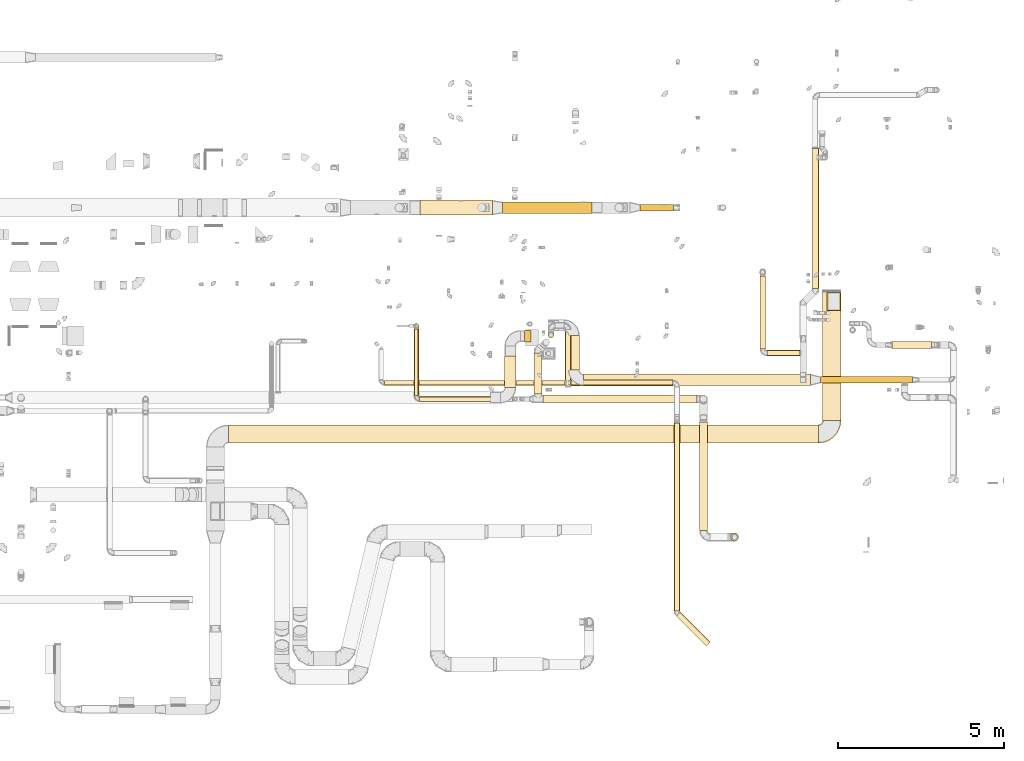
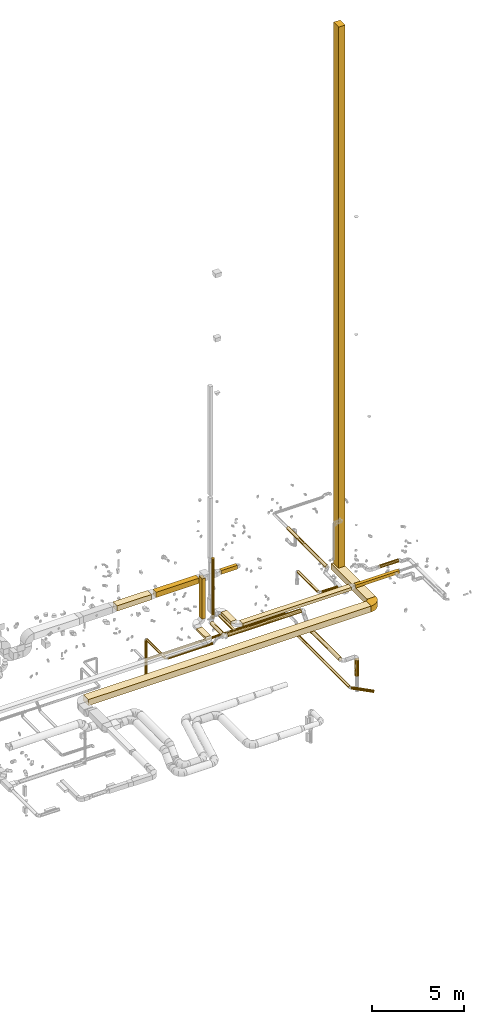
# One storey, part 3 of 97: 29 coverings.
"""IFC2X3 building model written with IfcOpenShell, lengths in millimetres."""

from ifc_helpers import new_model, entity, si_unit, converted_unit, derived_unit, direction, frame, frame_2d, origin, origin_2d_with_axis, place, context, subcontext, project, spatial, polyline, circle_curve, parameter, trimmed, segment, composite_curve, rectangle, circle, outline, extrude, element, save


model = new_model("IFC2X3")

# Units and contexts
model_context = context("Model", 3, precision=0.01, world=origin(), true_north=direction((6.12303176911189e-17, 1.0)))
body_context = subcontext(model_context, "Body", "Model", "MODEL_VIEW")
ifc_project = project(units=[si_unit("LENGTHUNIT", "METRE", prefix="MILLI"), si_unit("AREAUNIT", "SQUARE_METRE"), si_unit("VOLUMEUNIT", "CUBIC_METRE"), converted_unit("PLANEANGLEUNIT", "DEGREE", entity("IfcRatioMeasure", 0.0174532925199433), si_unit("PLANEANGLEUNIT", "RADIAN"), dimensions=[0, 0, 0, 0, 0, 0, 0]), si_unit("MASSUNIT", "GRAM", prefix="KILO"), derived_unit("MASSDENSITYUNIT", [(si_unit("MASSUNIT", "GRAM", prefix="KILO"), 1), (si_unit("LENGTHUNIT", "METRE"), -3)]), derived_unit("MOMENTOFINERTIAUNIT", [(si_unit("LENGTHUNIT", "METRE"), 4)]), si_unit("TIMEUNIT", "SECOND"), si_unit("FREQUENCYUNIT", "HERTZ"), si_unit("THERMODYNAMICTEMPERATUREUNIT", "DEGREE_CELSIUS"), derived_unit("THERMALTRANSMITTANCEUNIT", [(si_unit("MASSUNIT", "GRAM", prefix="KILO"), 1), (si_unit("THERMODYNAMICTEMPERATUREUNIT", "KELVIN"), -1), (si_unit("TIMEUNIT", "SECOND"), -3)]), derived_unit("VOLUMETRICFLOWRATEUNIT", [(si_unit("LENGTHUNIT", "METRE"), 3), (si_unit("TIMEUNIT", "SECOND"), -1)]), derived_unit("MASSFLOWRATEUNIT", [(si_unit("MASSUNIT", "GRAM", prefix="KILO"), 1), (si_unit("TIMEUNIT", "SECOND"), -1)]), derived_unit("ROTATIONALFREQUENCYUNIT", [(si_unit("TIMEUNIT", "SECOND"), -1)]), si_unit("ELECTRICCURRENTUNIT", "AMPERE"), si_unit("ELECTRICVOLTAGEUNIT", "VOLT"), si_unit("POWERUNIT", "WATT"), si_unit("FORCEUNIT", "NEWTON", prefix="KILO"), si_unit("ILLUMINANCEUNIT", "LUX"), si_unit("LUMINOUSFLUXUNIT", "LUMEN"), si_unit("LUMINOUSINTENSITYUNIT", "CANDELA"), derived_unit("USERDEFINED", [(si_unit("MASSUNIT", "GRAM", prefix="KILO"), -1), (si_unit("LENGTHUNIT", "METRE"), -2), (si_unit("TIMEUNIT", "SECOND"), 3), (si_unit("LUMINOUSFLUXUNIT", "LUMEN"), 1)]), derived_unit("LINEARVELOCITYUNIT", [(si_unit("LENGTHUNIT", "METRE"), 1), (si_unit("TIMEUNIT", "SECOND"), -1)]), si_unit("PRESSUREUNIT", "PASCAL"), derived_unit("USERDEFINED", [(si_unit("LENGTHUNIT", "METRE"), -2), (si_unit("MASSUNIT", "GRAM", prefix="KILO"), 1), (si_unit("TIMEUNIT", "SECOND"), -2)]), derived_unit("LINEARFORCEUNIT", [(si_unit("MASSUNIT", "GRAM", prefix="KILO"), 1), (si_unit("LENGTHUNIT", "METRE"), 1), (si_unit("TIMEUNIT", "SECOND"), -2), (si_unit("LENGTHUNIT", "METRE"), -1)]), derived_unit("PLANARFORCEUNIT", [(si_unit("MASSUNIT", "GRAM", prefix="KILO"), 1), (si_unit("LENGTHUNIT", "METRE"), 1), (si_unit("TIMEUNIT", "SECOND"), -2), (si_unit("LENGTHUNIT", "METRE"), -2)])], contexts=[model_context])

# Site, building, storey
site_placement = place(None, origin())
site = spatial("IfcSite", under=ifc_project, at=site_placement, CompositionType="ELEMENT")
building_placement = place(site_placement, origin())
building = spatial("IfcBuilding", under=site, at=building_placement, CompositionType="ELEMENT")
storey_placement = place(building_placement, frame((0.0, 0.0, -4900.0)))
storey = spatial("IfcBuildingStorey", under=building, at=storey_placement, CompositionType="ELEMENT", Elevation=-4900.0)

# Coverings
covering_1_placement = place(storey_placement, frame((67714.12, 8950.37, 3780.0)))
element("IfcCovering", 1, at=covering_1_placement, inside=storey, PredefinedType="INSULATION", context=body_context, shape_type="SweptSolid", body=[
    extrude(rectangle(XDim=3877.70991000002, YDim=549.999999999996, at=origin_2d_with_axis()), frame((275.0, 1938.85, 0.0), z_axis=(0.0, 0.0, 1.0), x_axis=(0.0, -1.0, 0.0)), (0.0, 0.0, 1.0), 400.0),
])
covering_2_placement = place(storey_placement, frame((49863.6, 8275.37, 3780.0)))
element("IfcCovering", 2, at=covering_2_placement, inside=storey, PredefinedType="INSULATION", context=body_context, shape_type="SweptSolid", body=[
    extrude(rectangle(XDim=17725.52076, YDim=550.000000000001, at=origin_2d_with_axis()), frame((8862.76, 275.0, 0.0), z_axis=(0.0, 0.0, 1.0), x_axis=(-1.0, 0.0, 0.0)), (0.0, 0.0, 1.0), 400.0),
])
covering_3_placement = place(storey_placement, frame((67849.81, 12253.05, 4179.89)))
element("IfcCovering", 3, at=covering_3_placement, inside=storey, PredefinedType="INSULATION", context=body_context, shape_type="SweptSolid", body=[
    extrude(rectangle(XDim=550.000000000001, YDim=399.999999999996, at=origin_2d_with_axis()), frame((200.0, 275.0, 0.0), z_axis=(0.0, 0.0, 1.0), x_axis=(0.0, 1.0, 0.0)), (0.0, 0.0, 1.0), 35850.1092108574),
])
covering_4_placement = place(storey_placement, frame((59035.41, 9748.98, 4223.4)))
element("IfcCovering", 4, at=covering_4_placement, inside=storey, PredefinedType="INSULATION", context=body_context, shape_type="SweptSolid", body=[
    extrude(circle(Radius=125.0, at=origin_2d_with_axis()), frame((126.6, 0.0, 126.6), z_axis=(0.0, 1.0, 0.0), x_axis=(-1.0, 0.0, 0.0)), (0.0, 0.0, 1.0), 1225.42779752531),
])
covering_5_placement = place(storey_placement, frame((55604.18, 9522.39, 4038.4)))
element("IfcCovering", 5, at=covering_5_placement, inside=storey, PredefinedType="INSULATION", context=body_context, shape_type="SweptSolid", body=[
    extrude(circle(Radius=75.0, at=origin_2d_with_axis()), frame((0.0, 76.6, 76.6), z_axis=(1.0, 0.0, 0.0), x_axis=(0.0, -1.0, 0.0)), (0.0, 0.0, 1.0), 2811.83896376268),
])
covering_6_placement = place(storey_placement, frame((55427.58, 9698.98, 4038.4)))
element("IfcCovering", 6, at=covering_6_placement, inside=storey, PredefinedType="INSULATION", context=body_context, shape_type="SweptSolid", body=[
    extrude(circle(Radius=75.0, at=origin_2d_with_axis()), frame((76.6, 0.0, 76.6), z_axis=(0.0, 1.0, 0.0), x_axis=(-1.0, 0.0, 0.0)), (0.0, 0.0, 1.0), 1997.18633000003),
])
covering_7_placement = place(storey_placement, frame((55427.58, 11719.57, 1175.0)))
element("IfcCovering", 7, at=covering_7_placement, inside=storey, PredefinedType="INSULATION", context=body_context, shape_type="SweptSolid", body=[
    extrude(circle(Radius=75.0, at=origin_2d_with_axis()), frame((76.6, 76.6, 0.0)), (0.0, 0.0, 1.0), 2840.00000000001),
])
covering_8_placement = place(storey_placement, frame((64007.19, 5648.45, 3323.4)))
element("IfcCovering", 8, at=covering_8_placement, inside=storey, PredefinedType="INSULATION", context=body_context, shape_type="SweptSolid", body=[
    extrude(circle(Radius=125.0, at=origin_2d_with_axis()), frame((126.6, 0.0, 126.6), z_axis=(0.0, 1.0, 0.0), x_axis=(-1.0, 0.0, 0.0)), (0.0, 0.0, 1.0), 3257.69167752536),
])
covering_9_placement = place(storey_placement, frame((60060.27, 10474.06, 4250.0)))
element("IfcCovering", 9, at=covering_9_placement, inside=storey, PredefinedType="INSULATION", context=body_context, shape_type="SweptSolid", body=[
    extrude(rectangle(XDim=1040.13836000004, YDim=350.000000000007, at=origin_2d_with_axis()), frame((175.0, 520.07, 0.0), z_axis=(0.0, 0.0, 1.0), x_axis=(0.0, -1.0, 0.0)), (0.0, 0.0, 1.0), 200.0),
])
covering_10_placement = place(storey_placement, frame((60535.27, 9999.06, 4250.0)))
element("IfcCovering", 10, at=covering_10_placement, inside=storey, PredefinedType="INSULATION", context=body_context, shape_type="SweptSolid", body=[
    extrude(rectangle(XDim=6820.00000000004, YDim=349.999999999998, at=origin_2d_with_axis()), frame((3410.0, 175.0, 0.0)), (0.0, 0.0, 1.0), 200.0),
])
covering_11_placement = place(storey_placement, frame((67655.27, 10074.06, 4250.0)))
element("IfcCovering", 11, at=covering_11_placement, inside=storey, PredefinedType="INSULATION", context=body_context, shape_type="SweptSolid", body=[
    extrude(rectangle(XDim=2759.99999999994, YDim=199.999999999998, at=origin_2d_with_axis()), frame((1380.0, 100.0, 0.0)), (0.0, 0.0, 1.0), 200.0),
])
covering_12_placement = place(storey_placement, frame((67387.61, 12917.82, 3893.4)))
element("IfcCovering", 12, at=covering_12_placement, inside=storey, PredefinedType="INSULATION", context=body_context, shape_type="SweptSolid", body=[
    extrude(circle(Radius=105.0, at=origin_2d_with_axis()), frame((106.6, 0.0, 106.6), z_axis=(0.0, 1.0, 0.0), x_axis=(-1.0, 0.0, 0.0)), (0.0, 0.0, 1.0), 4214.22306685089),
])
covering_13_placement = place(storey_placement, frame((66038.93, 10891.13, 3910.9)))
element("IfcCovering", 13, at=covering_13_placement, inside=storey, PredefinedType="INSULATION", context=body_context, shape_type="SweptSolid", body=[
    extrude(circle(Radius=87.5, at=origin_2d_with_axis()), frame((0.0, 89.1, 89.1), z_axis=(1.0, 0.0, 0.0), x_axis=(0.0, 1.0, 0.0)), (0.0, 0.0, 1.0), 995.793749999996),
])
covering_14_placement = place(storey_placement, frame((65824.84, 11105.22, 3910.9)))
element("IfcCovering", 14, at=covering_14_placement, inside=storey, PredefinedType="INSULATION", context=body_context, shape_type="SweptSolid", body=[
    extrude(circle(Radius=87.5, at=origin_2d_with_axis()), frame((89.1, 0.0, 89.1), z_axis=(0.0, 1.0, 0.0), x_axis=(-1.0, 0.0, 0.0)), (0.0, 0.0, 1.0), 2182.57919999999),
])
covering_15_placement = place(storey_placement, frame((69801.87, 11116.98, 4118.4)))
element("IfcCovering", 15, at=covering_15_placement, inside=storey, PredefinedType="INSULATION", context=body_context, shape_type="SweptSolid", body=[
    extrude(circle(Radius=105.0, at=origin_2d_with_axis()), frame((0.0, 106.6, 106.6), z_axis=(1.0, 0.0, 0.0), x_axis=(0.0, 1.0, 0.0)), (0.0, 0.0, 1.0), 1181.52376700002),
])
covering_16_placement = place(storey_placement, frame((59973.56, 10005.87, 4025.9)))
element("IfcCovering", 16, at=covering_16_placement, inside=storey, PredefinedType="INSULATION", context=body_context, shape_type="SweptSolid", body=[
    extrude(circle(Radius=87.5, at=origin_2d_with_axis()), frame((89.1, 0.0, 89.1), z_axis=(0.0, 1.0, 0.0), x_axis=(1.0, 0.0, 0.0)), (0.0, 0.0, 1.0), 1675.0),
])
covering_17_placement = place(storey_placement, frame((54546.9, 10006.99, 4038.4)))
element("IfcCovering", 17, at=covering_17_placement, inside=storey, PredefinedType="INSULATION", context=body_context, shape_type="SweptSolid", body=[
    extrude(circle(Radius=75.0, at=origin_2d_with_axis()), frame((0.0, 76.6, 76.6), z_axis=(1.0, 0.0, 0.0), x_axis=(0.0, 1.0, 0.0)), (0.0, 0.0, 1.0), 5433.24657999997),
])
covering_18_placement = place(storey_placement, frame((60145.15, 9994.49, 4025.9)))
element("IfcCovering", 18, at=covering_18_placement, inside=storey, PredefinedType="INSULATION", context=body_context, shape_type="SweptSolid", body=[
    extrude(circle(Radius=87.5, at=origin_2d_with_axis()), frame((0.0, 89.1, 89.1), z_axis=(1.0, 0.0, 0.0), x_axis=(0.0, -1.0, 0.0)), (0.0, 0.0, 1.0), 3067.9582299999),
])
covering_19_placement = place(storey_placement, frame((63249.01, 3226.48, 3260.9)))
element("IfcCovering", 19, at=covering_19_placement, inside=storey, PredefinedType="INSULATION", context=body_context, shape_type="SweptSolid", body=[
    extrude(circle(Radius=87.5, at=origin_2d_with_axis()), frame((89.1, 0.0, 89.1), z_axis=(0.0, 1.0, 0.0), x_axis=(-1.0, 0.0, 0.0)), (0.0, 0.0, 1.0), 5649.58886470343),
])
covering_20_placement = place(storey_placement, frame((63311.25, 2173.97, 3260.9)))
element("IfcCovering", 20, at=covering_20_placement, inside=storey, PredefinedType="INSULATION", context=body_context, shape_type="SweptSolid", body=[
    extrude(circle(Radius=87.5, at=origin_2d_with_axis()), frame((964.12, 63.47, 89.1), z_axis=(-0.707106781186597, 0.707106781186498, 0.0), x_axis=(0.707106781186498, 0.707106781186597, 0.0)), (0.0, 0.0, 1.0), 1273.71806347082),
])
covering_21_placement = place(storey_placement, frame((59460.89, 11435.8, 4240.0)))
element("IfcCovering", 21, at=covering_21_placement, inside=storey, PredefinedType="INSULATION", context=body_context, shape_type="SweptSolid", body=[
    extrude(circle(Radius=87.5, at=origin_2d_with_axis()), frame((89.1, 89.1, 0.0)), (0.0, 0.0, 1.0), 3955.00000070971),
])
covering_22_placement = place(storey_placement, frame((58154.81, 9943.15, 4250.0)))
element("IfcCovering", 22, at=covering_22_placement, inside=storey, PredefinedType="INSULATION", context=body_context, shape_type="SweptSolid", body=[
    extrude(rectangle(XDim=944.720900000099, YDim=350.000000000007, at=origin_2d_with_axis()), frame((175.0, 472.36, 0.0), z_axis=(0.0, 0.0, 1.0), x_axis=(0.0, -1.0, 0.0)), (0.0, 0.0, 1.0), 150.0),
])
covering_23_placement = place(storey_placement, frame((58754.81, 11312.87, 4550.0)))
element("IfcCovering", 23, at=covering_23_placement, inside=storey, PredefinedType="INSULATION", context=body_context, shape_type="SweptSolid", body=[
    extrude(rectangle(XDim=199.999999999992, YDim=349.999999999998, at=origin_2d_with_axis()), frame((100.0, 175.0, 0.0), z_axis=(3.65753741356617e-05, 0.0, 1.0), x_axis=(-1.0, 0.0, 3.65753741356617e-05)), (0.0, 0.0, 1.0), 2670.00002678592),
])
covering_24_placement = place(storey_placement, frame((59312.01, 9472.39, 4223.4)))
element("IfcCovering", 24, at=covering_24_placement, inside=storey, PredefinedType="INSULATION", context=body_context, shape_type="SweptSolid", body=[
    extrude(circle(Radius=125.0, at=origin_2d_with_axis()), frame((0.0, 126.6, 126.6), z_axis=(1.0, 0.0, 0.0), x_axis=(0.0, 1.0, 0.0)), (0.0, 0.0, 1.0), 4621.77068899),
])
covering_25_placement = place(storey_placement, frame((55615.5, 15123.96, 3875.0)))
element("IfcCovering", 25, at=covering_25_placement, inside=storey, PredefinedType="INSULATION", context=body_context, shape_type="SweptSolid", body=[
    extrude(rectangle(XDim=2175.17176975001, YDim=450.000000000002, at=origin_2d_with_axis()), frame((1087.59, 225.0, 0.0)), (0.0, 0.0, 1.0), 350.0),
])
covering_26_placement = place(storey_placement, frame((58090.67, 15173.96, 3875.0)))
element("IfcCovering", 26, at=covering_26_placement, inside=storey, PredefinedType="INSULATION", context=body_context, shape_type="SweptSolid", body=[
    extrude(rectangle(XDim=2690.26260986296, YDim=349.999999999998, at=origin_2d_with_axis()), frame((1345.13, 175.0, 0.0)), (0.0, 0.0, 1.0), 350.0),
])
covering_27_placement = place(storey_placement, frame((62220.37, 15248.96, 3925.0)))
element("IfcCovering", 27, at=covering_27_placement, inside=storey, PredefinedType="INSULATION", context=body_context, shape_type="SweptSolid", body=[
    extrude(rectangle(XDim=1006.91276425047, YDim=199.999999999998, at=origin_2d_with_axis()), frame((503.46, 100.0, 0.0)), (0.0, 0.0, 1.0), 250.0),
])
covering_28_placement = place(storey_placement, frame((64936.87, 5321.85, 2188.01)))
element("IfcCovering", 28, at=covering_28_placement, inside=storey, PredefinedType="INSULATION", context=body_context, shape_type="SweptSolid", body=[
    extrude(circle(Radius=125.0, at=origin_2d_with_axis()), frame((126.6, 126.6, 0.0), z_axis=(0.0, 0.0, 1.0), x_axis=(0.0, -1.0, 0.0)), (0.0, 0.0, 1.0), 1061.986871),
])
covering_29_placement = place(storey_placement, frame((67587.52, 8273.77, 3780.0)))
element("IfcCovering", 29, at=covering_29_placement, inside=storey, PredefinedType="INSULATION", context=body_context, shape_type="SweptSolid", body=[
    extrude(outline(composite_curve([segment(polyline([(-200.0, 75.0), (-200.0, -475.0)]), True, "CONTINUOUS"), segment(trimmed(circle_curve(frame_2d((-200.0, 200.0), x_axis=(1.0, 0.0)), 675.0), [parameter(270.0)], [parameter(0.0)], True, "PARAMETER"), True, "CONTINUOUS"), segment(polyline([(475.0, 200.0), (-75.0, 200.0)]), True, "CONTINUOUS"), segment(trimmed(circle_curve(frame_2d((-200.0, 200.0), x_axis=(1.0, 0.0)), 125.0), [parameter(270.0)], [parameter(360.0)], True, "PARAMETER"), False, "CONTINUOUS")], self_intersect=False)), frame((201.6, 476.6, 0.0), z_axis=(0.0, 0.0, -1.0), x_axis=(0.0, -1.0, 0.0)), (0.0, 0.0, -1.0), 400.0),
])

save(model, "model.ifc")
